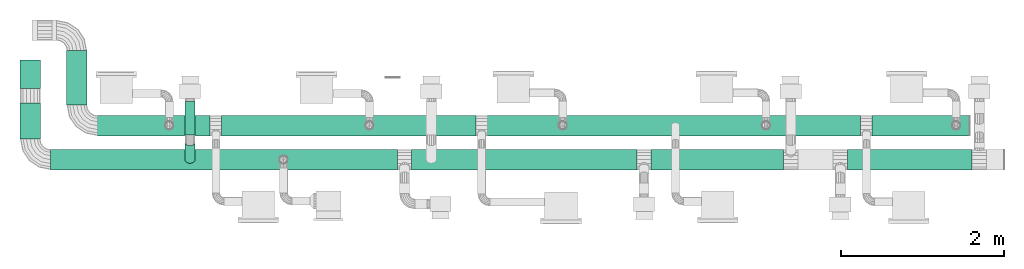
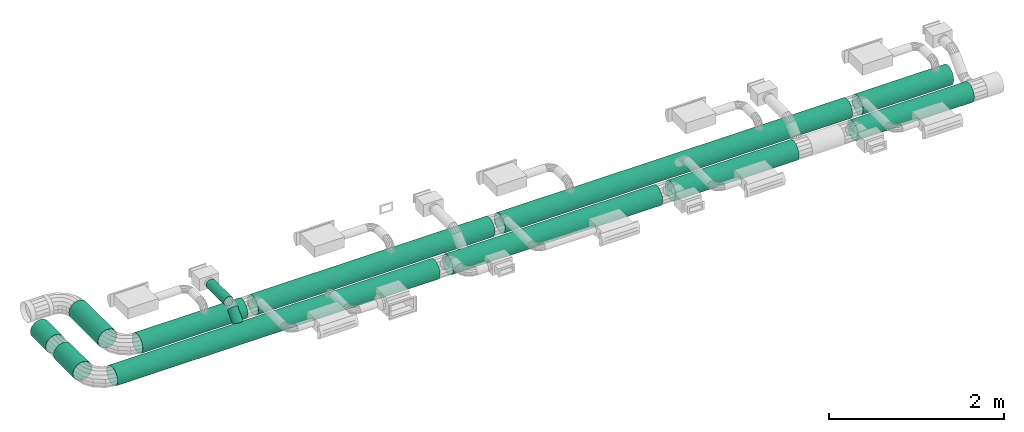
# One storey, part 1 of 11: 13 flow segments.
"""IFC2X3 building model written with IfcOpenShell, lengths in millimetres."""

from ifc_helpers import new_model, si_unit, derived_unit, frame, origin_with_axes, origin_2d_with_axis, place, context, project, spatial, hollow_circle, extrude, source, transform, mapped, type_object, element, save


model = new_model("IFC2X3")

# Units and contexts
context_of_model = context(None, 3, precision=1e-05, world=origin_with_axes())
ifc_project = project(units=[si_unit("LENGTHUNIT", "METRE", prefix="MILLI"), si_unit("AREAUNIT", "SQUARE_METRE"), si_unit("VOLUMEUNIT", "CUBIC_METRE"), si_unit("PLANEANGLEUNIT", "RADIAN"), si_unit("TIMEUNIT", "SECOND"), si_unit("POWERUNIT", "WATT"), si_unit("THERMODYNAMICTEMPERATUREUNIT", "DEGREE_CELSIUS"), derived_unit("VOLUMETRICFLOWRATEUNIT", [(si_unit("VOLUMEUNIT", "CUBIC_METRE"), 1), (si_unit("TIMEUNIT", "SECOND"), -1)])], contexts=[context_of_model])

# Site, building, storey
site_placement = place(None, origin_with_axes())
site = spatial("IfcSite", under=ifc_project, at=site_placement, CompositionType="ELEMENT")
building_placement = place(site_placement, origin_with_axes())
building = spatial("IfcBuilding", under=site, at=building_placement, CompositionType="ELEMENT")
storey_placement = place(building_placement, frame((0.0, 0.0, 3800.0), z_axis=(0.0, 0.0, 1.0), x_axis=(1.0, 0.0, 0.0)))
storey = spatial("IfcBuildingStorey", under=building, at=storey_placement, Name="First floor", CompositionType="ELEMENT")

# Flow segments
duct_segment_type_1 = type_object("IfcDuctSegmentType", PredefinedType="RIGIDSEGMENT")
shared_shape_1 = source(origin_with_axes(), context_of_model, "Body", "SweptSolid", [
    extrude(hollow_circle(Radius=63.0, WallThickness=2.0, at=origin_2d_with_axis()), frame((0.0, 0.0, 0.0), z_axis=(1.0, 0.0, 0.0), x_axis=(0.0, 1.0, 0.0)), (0.0, 0.0, 1.0), 306.0),
])
flow_segment_1_placement = place(storey_placement, frame((4910.91447, 4463.3661, 2566.12943), z_axis=(0.0, -0.707107, 0.707107), x_axis=(0.0, -0.707107, -0.707107)))
element("IfcFlowSegment", 1, at=flow_segment_1_placement, inside=storey, type_object=duct_segment_type_1, context=context_of_model, shape_type="MappedRepresentation", body=[
    mapped(shared_shape_1, transform((0.0, 0.0, 0.0), scale=1.0)),
])
duct_segment_type_2 = type_object("IfcDuctSegmentType", PredefinedType="RIGIDSEGMENT")
shared_shape_2 = source(origin_with_axes(), context_of_model, "Body", "SweptSolid", [
    extrude(hollow_circle(Radius=63.0, WallThickness=2.0, at=origin_2d_with_axis()), frame((0.0, 0.0, 0.0), z_axis=(1.0, 0.0, 0.0), x_axis=(0.0, 1.0, 0.0)), (0.0, 0.0, 1.0), 306.0),
])
flow_segment_2_placement = place(storey_placement, frame((4910.91447, 4957.70026, 2602.74108), z_axis=(0.0, 0.0, 1.0), x_axis=(0.0, -1.0, 0.0)))
element("IfcFlowSegment", 2, at=flow_segment_2_placement, inside=storey, type_object=duct_segment_type_2, context=context_of_model, shape_type="MappedRepresentation", body=[
    mapped(shared_shape_2, transform((0.0, 0.0, 0.0), scale=1.328126, scale2=1.0, scale3=1.0, uniform=False)),
])
duct_segment_type_3 = type_object("IfcDuctSegmentType", PredefinedType="RIGIDSEGMENT")
shared_shape_3 = source(origin_with_axes(), context_of_model, "Body", "SweptSolid", [
    extrude(hollow_circle(Radius=63.0, WallThickness=2.0, at=origin_2d_with_axis()), frame((0.0, 0.0, 0.0), z_axis=(1.0, 0.0, 0.0), x_axis=(0.0, 1.0, 0.0)), (0.0, 0.0, 1.0), 306.0),
])
flow_segment_3_placement = place(storey_placement, frame((12173.39272, 4247.23667, 2350.0), z_axis=(0.0, 0.0, 1.0), x_axis=(-1.0, 0.0, 0.0)))
element("IfcFlowSegment", 3, at=flow_segment_3_placement, inside=storey, type_object=duct_segment_type_3, context=context_of_model, shape_type="MappedRepresentation", body=[
    mapped(shared_shape_3, transform((0.0, 0.0, 0.0), scale=5.29866, scale2=2.0, scale3=2.0, uniform=False)),
])
duct_segment_type_4 = type_object("IfcDuctSegmentType", PredefinedType="RIGIDSEGMENT")
shared_shape_4 = source(origin_with_axes(), context_of_model, "Body", "SweptSolid", [
    extrude(hollow_circle(Radius=63.0, WallThickness=2.0, at=origin_2d_with_axis()), frame((0.0, 0.0, 0.0), z_axis=(1.0, 0.0, 0.0), x_axis=(0.0, 1.0, 0.0)), (0.0, 0.0, 1.0), 306.0),
])
flow_segment_4_placement = place(storey_placement, frame((14480.10117, 4247.23667, 2350.0), z_axis=(0.0, 0.0, 1.0), x_axis=(-1.0, 0.0, 0.0)))
element("IfcFlowSegment", 4, at=flow_segment_4_placement, inside=storey, type_object=duct_segment_type_4, context=context_of_model, shape_type="MappedRepresentation", body=[
    mapped(shared_shape_4, transform((0.0, 0.0, 0.0), scale=4.992113, scale2=2.0, scale3=2.0, uniform=False)),
])
duct_segment_type_5 = type_object("IfcDuctSegmentType", PredefinedType="RIGIDSEGMENT")
shared_shape_5 = source(origin_with_axes(), context_of_model, "Body", "SweptSolid", [
    extrude(hollow_circle(Radius=63.0, WallThickness=2.0, at=origin_2d_with_axis()), frame((0.0, 0.0, 0.0), z_axis=(1.0, 0.0, 0.0), x_axis=(0.0, 1.0, 0.0)), (0.0, 0.0, 1.0), 306.0),
])
flow_segment_5_placement = place(storey_placement, frame((14450.10973, 4663.86746, 2350.0), z_axis=(0.0, 0.0, 1.0), x_axis=(-1.0, 0.0, 0.0)))
element("IfcFlowSegment", 5, at=flow_segment_5_placement, inside=storey, type_object=duct_segment_type_5, context=context_of_model, shape_type="MappedRepresentation", body=[
    mapped(shared_shape_5, transform((0.0, 0.0, 0.0), scale=3.905962, scale2=2.0, scale3=2.0, uniform=False)),
])
duct_segment_type_6 = type_object("IfcDuctSegmentType", PredefinedType="RIGIDSEGMENT")
shared_shape_6 = source(origin_with_axes(), context_of_model, "Body", "SweptSolid", [
    extrude(hollow_circle(Radius=63.0, WallThickness=2.0, at=origin_2d_with_axis()), frame((0.0, 0.0, 0.0), z_axis=(1.0, 0.0, 0.0), x_axis=(0.0, 1.0, 0.0)), (0.0, 0.0, 1.0), 306.0),
])
flow_segment_6_placement = place(storey_placement, frame((3526.65374, 4913.86746, 2350.0), z_axis=(0.0, 0.0, 1.0), x_axis=(0.0, 1.0, 0.0)))
element("IfcFlowSegment", 6, at=flow_segment_6_placement, inside=storey, type_object=duct_segment_type_6, context=context_of_model, shape_type="MappedRepresentation", body=[
    mapped(shared_shape_6, transform((0.0, 0.0, 0.0), scale=2.17887, scale2=2.0, scale3=2.0, uniform=False)),
])
duct_segment_type_7 = type_object("IfcDuctSegmentType", PredefinedType="RIGIDSEGMENT")
shared_shape_7 = source(origin_with_axes(), context_of_model, "Body", "SweptSolid", [
    extrude(hollow_circle(Radius=63.0, WallThickness=2.0, at=origin_2d_with_axis()), frame((0.0, 0.0, 0.0), z_axis=(1.0, 0.0, 0.0), x_axis=(0.0, 1.0, 0.0)), (0.0, 0.0, 1.0), 306.0),
])
flow_segment_7_placement = place(storey_placement, frame((2956.58095, 5118.54909, 2350.0), z_axis=(0.0, 0.0, 1.0), x_axis=(0.0, 1.0, 0.0)))
element("IfcFlowSegment", 7, at=flow_segment_7_placement, inside=storey, type_object=duct_segment_type_7, context=context_of_model, shape_type="MappedRepresentation", body=[
    mapped(shared_shape_7, transform((0.0, 0.0, 0.0), scale=1.144133, scale2=2.0, scale3=2.0, uniform=False)),
])
duct_segment_type_8 = type_object("IfcDuctSegmentType", PredefinedType="RIGIDSEGMENT")
shared_shape_8 = source(origin_with_axes(), context_of_model, "Body", "SweptSolid", [
    extrude(hollow_circle(Radius=63.0, WallThickness=2.0, at=origin_2d_with_axis()), frame((0.0, 0.0, 0.0), z_axis=(1.0, 0.0, 0.0), x_axis=(0.0, 1.0, 0.0)), (0.0, 0.0, 1.0), 306.0),
])
flow_segment_8_placement = place(storey_placement, frame((10378.84041, 4247.23667, 2350.0), z_axis=(0.0, 0.0, 1.0), x_axis=(-1.0, 0.0, 0.0)))
element("IfcFlowSegment", 8, at=flow_segment_8_placement, inside=storey, type_object=duct_segment_type_8, context=context_of_model, shape_type="MappedRepresentation", body=[
    mapped(shared_shape_8, transform((0.0, 0.0, 0.0), scale=9.016066, scale2=2.0, scale3=2.0, uniform=False)),
])
duct_segment_type_9 = type_object("IfcDuctSegmentType", PredefinedType="RIGIDSEGMENT")
shared_shape_9 = source(origin_with_axes(), context_of_model, "Body", "SweptSolid", [
    extrude(hollow_circle(Radius=63.0, WallThickness=2.0, at=origin_2d_with_axis()), frame((0.0, 0.0, 0.0), z_axis=(1.0, 0.0, 0.0), x_axis=(0.0, 1.0, 0.0)), (0.0, 0.0, 1.0), 306.0),
])
flow_segment_9_placement = place(storey_placement, frame((7448.05138, 4247.23667, 2350.0), z_axis=(0.0, 0.0, 1.0), x_axis=(-1.0, 0.0, 0.0)))
element("IfcFlowSegment", 9, at=flow_segment_9_placement, inside=storey, type_object=duct_segment_type_9, context=context_of_model, shape_type="MappedRepresentation", body=[
    mapped(shared_shape_9, transform((0.0, 0.0, 0.0), scale=13.876743, scale2=2.0, scale3=2.0, uniform=False)),
])
duct_segment_type_10 = type_object("IfcDuctSegmentType", PredefinedType="RIGIDSEGMENT")
shared_shape_10 = source(origin_with_axes(), context_of_model, "Body", "SweptSolid", [
    extrude(hollow_circle(Radius=63.0, WallThickness=2.0, at=origin_2d_with_axis()), frame((0.0, 0.0, 0.0), z_axis=(1.0, 0.0, 0.0), x_axis=(0.0, 1.0, 0.0)), (0.0, 0.0, 1.0), 306.0),
])
flow_segment_10_placement = place(storey_placement, frame((13116.23995, 4663.86746, 2350.0), z_axis=(0.0, 0.0, 1.0), x_axis=(-1.0, 0.0, 0.0)))
element("IfcFlowSegment", 10, at=flow_segment_10_placement, inside=storey, type_object=duct_segment_type_10, context=context_of_model, shape_type="MappedRepresentation", body=[
    mapped(shared_shape_10, transform((0.0, 0.0, 0.0), scale=14.940276, scale2=2.0, scale3=2.0, uniform=False)),
])
duct_segment_type_11 = type_object("IfcDuctSegmentType", PredefinedType="RIGIDSEGMENT")
shared_shape_11 = source(origin_with_axes(), context_of_model, "Body", "SweptSolid", [
    extrude(hollow_circle(Radius=63.0, WallThickness=2.0, at=origin_2d_with_axis()), frame((0.0, 0.0, 0.0), z_axis=(1.0, 0.0, 0.0), x_axis=(0.0, 1.0, 0.0)), (0.0, 0.0, 1.0), 306.0),
])
flow_segment_11_placement = place(storey_placement, frame((5158.1254, 4663.86746, 2350.0), z_axis=(0.0, 0.0, 1.0), x_axis=(-1.0, 0.0, 0.0)))
element("IfcFlowSegment", 11, at=flow_segment_11_placement, inside=storey, type_object=duct_segment_type_11, context=context_of_model, shape_type="MappedRepresentation", body=[
    mapped(shared_shape_11, transform((0.0, 0.0, 0.0), scale=4.519736, scale2=2.0, scale3=2.0, uniform=False)),
])
duct_segment_type_12 = type_object("IfcDuctSegmentType", PredefinedType="RIGIDSEGMENT")
shared_shape_12 = source(origin_with_axes(), context_of_model, "Body", "SweptSolid", [
    extrude(hollow_circle(Radius=63.0, WallThickness=2.0, at=origin_2d_with_axis()), frame((0.0, 0.0, 0.0), z_axis=(1.0, 0.0, 0.0), x_axis=(0.0, 1.0, 0.0)), (0.0, 0.0, 1.0), 306.0),
])
flow_segment_12_placement = place(storey_placement, frame((8409.69731, 4663.86746, 2350.0), z_axis=(0.0, 0.0, 1.0), x_axis=(-1.0, 0.0, 0.0)))
element("IfcFlowSegment", 12, at=flow_segment_12_placement, inside=storey, type_object=duct_segment_type_12, context=context_of_model, shape_type="MappedRepresentation", body=[
    mapped(shared_shape_12, transform((0.0, 0.0, 0.0), scale=10.180074, scale2=2.0, scale3=2.0, uniform=False)),
])
duct_segment_type_13 = type_object("IfcDuctSegmentType", PredefinedType="RIGIDSEGMENT")
shared_shape_13 = source(origin_with_axes(), context_of_model, "Body", "SweptSolid", [
    extrude(hollow_circle(Radius=63.0, WallThickness=2.0, at=origin_2d_with_axis()), frame((0.0, 0.0, 0.0), z_axis=(1.0, 0.0, 0.0), x_axis=(0.0, 1.0, 0.0)), (0.0, 0.0, 1.0), 306.0),
])
flow_segment_13_placement = place(storey_placement, frame((2956.58095, 4497.23667, 2350.0), z_axis=(0.0, 0.0, 1.0), x_axis=(0.0, 1.0, 0.0)))
element("IfcFlowSegment", 13, at=flow_segment_13_placement, inside=storey, type_object=duct_segment_type_13, context=context_of_model, shape_type="MappedRepresentation", body=[
    mapped(shared_shape_13, transform((0.0, 0.0, 0.0), scale=1.443834, scale2=2.0, scale3=2.0, uniform=False)),
])

save(model, "model.ifc")
